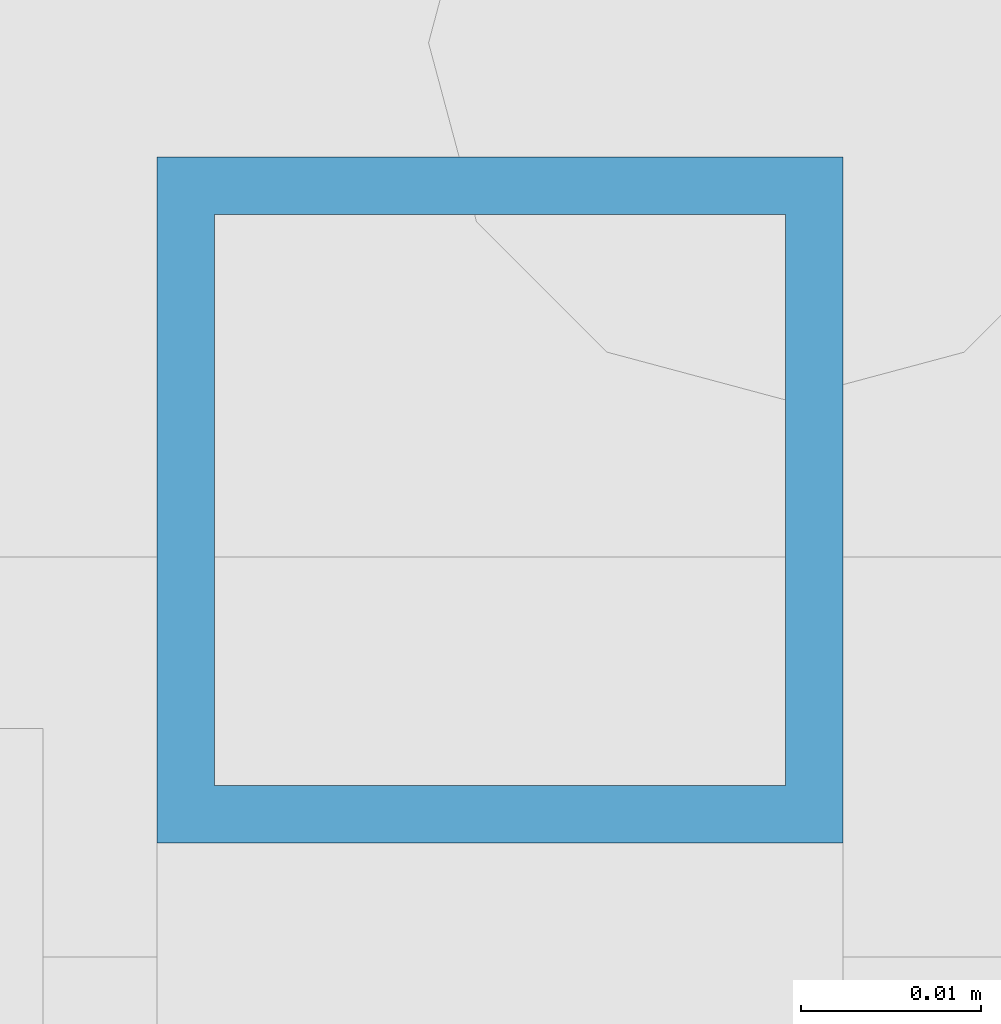
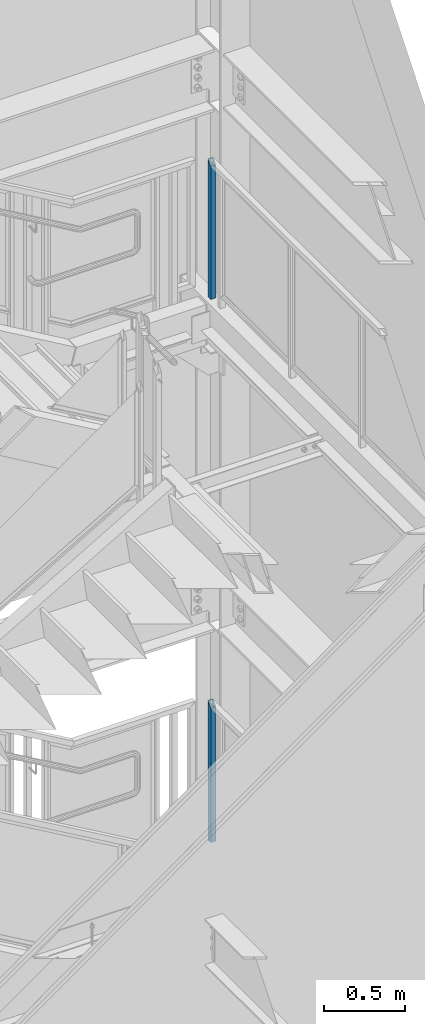
# One storey, part 378 of 1179: 2 columns, 2 elements without a shape of their own.
"""IFC2X3 building model written with IfcOpenShell, lengths in millimetres."""

import ifcopenshell
import ifcopenshell.guid

model = None  # the IFC model being written
_history = None  # IfcOwnerHistory: only IFC2X3 demands one
_inside = {}  # id of a spatial element -> (the spatial element, [elements in it])
_under = {}  # id of a project, library or spatial element -> (it, [spatial elements below it])
_declared = {}  # id of a project -> (the project, [libraries it declares])
_typed = {}  # id of a type object -> (the type object, [elements of that type])
_made_of = {}  # id of a material, layer set ... -> (it, [elements and type objects made of it])


def new_model(schema):
    """Start an empty IFC model of exactly this schema.

    Asked for "IFC4X3", IfcOpenShell would pick the latest addendum, in which some entities
    have other attributes; the version numbers below select the first issue.
    IFC2X3 requires an IfcOwnerHistory on every rooted entity: one is made here for all.
    """
    global model, _history
    if schema == "IFC4X3":
        model = ifcopenshell.file(schema_version=(4, 3, 0, 0))
    else:
        model = ifcopenshell.file(schema=schema)
    _inside.clear()
    _under.clear()
    _declared.clear()
    _typed.clear()
    _made_of.clear()
    _history = None
    if model.schema == "IFC2X3":
        org = make("IfcOrganization", Name="unknown")
        user = make(
            "IfcPersonAndOrganization",
            ThePerson=make("IfcPerson", FamilyName="unknown"),
            TheOrganization=org,
        )
        app = make(
            "IfcApplication",
            ApplicationDeveloper=org,
            Version="unknown",
            ApplicationFullName="unknown",
            ApplicationIdentifier="unknown",
        )
        _history = make(
            "IfcOwnerHistory",
            OwningUser=user,
            OwningApplication=app,
            ChangeAction="ADDED",
            CreationDate=0,
        )
    return model


def make(cls, **values):
    """One entity of the class cls with the attributes given. An attribute that is None is left unset."""
    return model.create_entity(
        cls, **{name: value for name, value in values.items() if value is not None}
    )


def rooted(cls, **values):
    """An entity with a GlobalId (a new one), such as an element, a storey or a relation."""
    return make(cls, GlobalId=ifcopenshell.guid.new(), OwnerHistory=_history, **values)


def si_unit(unit_type, name, prefix=None):
    """IfcSIUnit, for example si_unit("LENGTHUNIT", "METRE", prefix="MILLI")."""
    return make("IfcSIUnit", UnitType=unit_type, Prefix=prefix, Name=name)


def assignment(units):
    """IfcUnitAssignment: the units of a project."""
    return None if units is None else make("IfcUnitAssignment", Units=units)


def point(xyz):
    """IfcCartesianPoint."""
    return None if xyz is None else make("IfcCartesianPoint", Coordinates=xyz)


def direction(xyz):
    """IfcDirection."""
    return None if xyz is None else make("IfcDirection", DirectionRatios=xyz)


def frame(location, z_axis=None, x_axis=None):
    """IfcAxis2Placement3D, a coordinate frame: its origin and axes. An axis left out is left unset."""
    return make(
        "IfcAxis2Placement3D",
        Location=point(location),
        Axis=direction(z_axis),
        RefDirection=direction(x_axis),
    )


def origin_with_axes():
    """The frame at (0, 0, 0) with the z axis (0, 0, 1) and the x axis (1, 0, 0) written out."""
    return frame((0.0, 0.0, 0.0), z_axis=(0.0, 0.0, 1.0), x_axis=(1.0, 0.0, 0.0))


def place(relative_to, where):
    """IfcLocalPlacement: puts the frame where relative to a parent placement (None: the world)."""
    return make(
        "IfcLocalPlacement", PlacementRelTo=relative_to, RelativePlacement=where
    )


def context(
    kind, dimensions, precision=None, world=None, true_north=None, identifier=None
):
    """IfcGeometricRepresentationContext, for example the 3D "Model" context."""
    return make(
        "IfcGeometricRepresentationContext",
        ContextIdentifier=identifier,
        ContextType=kind,
        CoordinateSpaceDimension=dimensions,
        Precision=precision,
        WorldCoordinateSystem=world,
        TrueNorth=true_north,
    )


def subcontext(parent, identifier, kind, view, scale=None):
    """IfcGeometricRepresentationSubContext, for example "Body" below "Model"."""
    return make(
        "IfcGeometricRepresentationSubContext",
        ContextIdentifier=identifier,
        ContextType=kind,
        ParentContext=parent,
        TargetScale=scale,
        TargetView=view,
    )


def project(units=None, contexts=None):
    """IfcProject with its units and contexts."""
    return rooted(
        "IfcProject",
        Name="project",
        RepresentationContexts=contexts,
        UnitsInContext=assignment(units),
    )


def spatial(cls, under=None, at=None, **own):
    """A site, building, storey or space (cls), placed at a placement, below another one or the project."""
    s = rooted(cls, ObjectPlacement=at, **own)
    if under is not None:
        _under.setdefault(under.id(), (under, []))[1].append(s)
    return s


def faces_of(points, faces, orient=None, outer=None):
    """IfcFace entities. A face is a list of loops; a loop is a list of indices into points, from 0.

    orient and outer hold one flag for each loop. By default every Orientation is true, the
    first loop of a face is its IfcFaceOuterBound and the others are IfcFaceBound.
    """
    made = []
    for i, loops in enumerate(faces):
        bounds = []
        for j, loop in enumerate(loops):
            is_outer = j == 0 if outer is None else outer[i][j]
            bounds.append(
                make(
                    "IfcFaceOuterBound" if is_outer else "IfcFaceBound",
                    Bound=make("IfcPolyLoop", Polygon=[points[k] for k in loop]),
                    Orientation=True if orient is None else orient[i][j],
                )
            )
        made.append(make("IfcFace", Bounds=bounds))
    return made


def faceted_brep(points, faces, orient=None, outer=None, voids=None):
    """IfcFacetedBrep: a solid bounded by flat faces; with voids (closed shells), ...WithVoids."""
    shared = [point(p) for p in points]
    hull = make("IfcClosedShell", CfsFaces=faces_of(shared, faces, orient, outer))
    if voids is None:
        return make("IfcFacetedBrep", Outer=hull)
    return make(
        "IfcFacetedBrepWithVoids",
        Outer=hull,
        Voids=[
            make(cls, CfsFaces=faces_of(shared, fs, o, b)) for cls, fs, o, b in voids
        ],
    )


def shape(context_of_items, identifier, shape_type, items):
    """IfcShapeRepresentation: the items that make up one representation, for example the "Body"."""
    return make(
        "IfcShapeRepresentation",
        ContextOfItems=context_of_items,
        RepresentationIdentifier=identifier,
        RepresentationType=shape_type,
        Items=items,
    )


def material(Name=None, Category=None):
    """IfcMaterial."""
    return make("IfcMaterial", Name=Name, Category=Category)


def made_of(thing, what):
    """Note that an element or type object is made of a material, layer set ...; save() writes the relation."""
    if what is not None:
        _made_of.setdefault(what.id(), (what, []))[1].append(thing)
    return thing


def type_object(cls, material=None, **own):
    """A type object (cls), such as IfcWallType, which elements share."""
    return made_of(rooted(cls, **own), material)


def element(
    cls,
    number,
    at=None,
    inside=None,
    cuts=None,
    type_object=None,
    material=None,
    context=None,
    identifier="Body",
    shape_type=None,
    held_by="IfcProductDefinitionShape",
    body=None,
    shapes=None,
    **own,
):
    """One element of the class cls, such as IfcWall. Its Tag is "e" and its number.

    at: its placement. inside: the storey or other place that contains it. cuts: it is an
    opening in that element (IfcRelVoidsElement). A single representation is given by context,
    identifier, shape_type and body (its items); several are given by shapes. held_by: the class
    of the entity that holds the representations. save() writes the other relations.
    """
    e = rooted(cls, Tag="e%d" % number, ObjectPlacement=at, **own)
    if body is not None:
        shapes = [shape(context, identifier, shape_type, body)]
    if shapes is not None:
        e.Representation = make(held_by, Representations=shapes)
    if inside is not None:
        _inside.setdefault(inside.id(), (inside, []))[1].append(e)
    if cuts is not None:
        rooted(
            "IfcRelVoidsElement", RelatingBuildingElement=cuts, RelatedOpeningElement=e
        )
    if type_object is not None:
        _typed.setdefault(type_object.id(), (type_object, []))[1].append(e)
    return made_of(e, material)


def aggregate(whole, parts):
    """IfcRelAggregates: a whole, such as a stair, and the parts it consists of."""
    return rooted("IfcRelAggregates", RelatingObject=whole, RelatedObjects=parts)


def save(model, path):
    """Write the relations noted so far, then the file.

    IfcRelAggregates (storeys below a building ...), IfcRelContainedInSpatialStructure (elements
    in a storey), IfcRelDefinesByType, IfcRelAssociatesMaterial and IfcRelDeclares: one each for
    every whole, place, type object, material and project.
    """
    for whole, parts in _under.values():
        aggregate(whole, parts)
    for where, things in _inside.values():
        rooted(
            "IfcRelContainedInSpatialStructure",
            RelatedElements=things,
            RelatingStructure=where,
        )
    for kind, things in _typed.values():
        rooted("IfcRelDefinesByType", RelatedObjects=things, RelatingType=kind)
    for what, things in _made_of.values():
        rooted("IfcRelAssociatesMaterial", RelatedObjects=things, RelatingMaterial=what)
    for by, libraries in _declared.values():
        rooted("IfcRelDeclares", RelatingContext=by, RelatedDefinitions=libraries)
    model.write(path)


model = new_model("IFC2X3")

# Units and contexts
model_context = context("Model", 3, precision=1e-05, world=origin_with_axes())
body_context = subcontext(model_context, "Body", "Model", "MODEL_VIEW")
ifc_project = project(units=[si_unit("LENGTHUNIT", "METRE", prefix="MILLI"), si_unit("AREAUNIT", "SQUARE_METRE"), si_unit("VOLUMEUNIT", "CUBIC_METRE"), si_unit("MASSUNIT", "GRAM", prefix="KILO"), si_unit("TIMEUNIT", "SECOND"), si_unit("PLANEANGLEUNIT", "RADIAN"), si_unit("SOLIDANGLEUNIT", "STERADIAN"), si_unit("THERMODYNAMICTEMPERATUREUNIT", "DEGREE_CELSIUS"), si_unit("LUMINOUSINTENSITYUNIT", "LUMEN")], contexts=[model_context])

# Site, building, storey
site_placement = place(None, origin_with_axes())
site = spatial("IfcSite", under=ifc_project, at=site_placement, CompositionType="ELEMENT")
building_placement = place(site_placement, origin_with_axes())
building = spatial("IfcBuilding", under=site, at=building_placement, Name="Undefined", CompositionType="ELEMENT")
storey_placement = place(building_placement, origin_with_axes())
storey = spatial("IfcBuildingStorey", under=building, at=storey_placement, Name="Undefined", CompositionType="ELEMENT", Elevation=0.0)

# Assembly, column
assembly_1_placement = place(storey_placement, origin_with_axes())
assembly_1 = element("IfcElementAssembly", 1, at=assembly_1_placement, inside=storey, Name="GUARDRAIL", AssemblyPlace="NOTDEFINED", PredefinedType="RIGID_FRAME")
ifc_material = material()
column_type = type_object("IfcColumnType", Name="HSS1-1/2X1-1/2X1/8", PredefinedType="NOTDEFINED")
column_1_placement = place(assembly_1_placement, frame((24114.1250004143, 40995.6000000007, 6242.05), z_axis=(-1.0, 0.0, 0.0), x_axis=(0.0, 0.0, 1.0)))
column_1 = element("IfcColumn", 2, at=column_1_placement, type_object=column_type, material=ifc_material, Name="POST", ObjectType="HSS1-1/2X1-1/2X1/8", context=body_context, shape_type="Brep", body=[
    faceted_brep([(0.0, 15.8749992830017, -15.8749992829999), (0.0, -15.8749992830017, -15.8749992829999), (1000.12499987055, -15.874999282998, -15.8749992830017), (1031.87499843655, 15.874999282998, -15.8749992830017), (0.0, -15.8749992830017, 15.8749992829999), (1000.12499987055, -15.874999282998, 15.8749992830017), (0.0, 15.8749992830017, 15.8749992829999), (1031.87499843655, 15.874999282998, 15.8749992830017), (0.0, 19.0499992350015, -19.0499992349996), (0.0, 19.0499992350015, 19.0499992349996), (1035.05, 19.0499992350015, 19.0499992350015), (1035.05, 19.0499992350015, -19.0499992350015), (0.0, -19.0499992350015, 19.0499992349996), (996.949999918549, -19.0499992350015, 19.0499992350015), (0.0, -19.0499992350015, -19.0499992349996), (996.949999918549, -19.0499992350015, -19.0499992350015)], [[[0, 1, 2, 3]], [[1, 4, 5, 2]], [[4, 6, 7, 5]], [[6, 0, 3, 7]], [[8, 9, 10, 11]], [[9, 12, 13, 10]], [[12, 14, 15, 13]], [[14, 8, 11, 15]], [[13, 15, 11, 10], [5, 7, 3, 2]], [[14, 12, 9, 8], [6, 4, 1, 0]]]),
])
aggregate(assembly_1, [column_1])

assembly_2_placement = place(storey_placement, origin_with_axes())
assembly_2 = element("IfcElementAssembly", 3, at=assembly_2_placement, inside=storey, Name="GUARDRAIL", AssemblyPlace="NOTDEFINED", PredefinedType="RIGID_FRAME")
column_2_placement = place(assembly_2_placement, frame((24114.1250004143, 40995.6000000007, 2155.825), z_axis=(-1.0, 0.0, 0.0), x_axis=(0.0, 0.0, 1.0)))
column_2 = element("IfcColumn", 4, at=column_2_placement, type_object=column_type, material=ifc_material, Name="POST", ObjectType="HSS1-1/2X1-1/2X1/8", context=body_context, shape_type="Brep", body=[
    faceted_brep([(0.0, 15.8749992830017, -15.8749992829999), (0.0, -15.8749992830017, -15.8749992829999), (1012.82499987055, -15.874999282998, -15.8749992830017), (1044.57499843655, 15.874999282998, -15.8749992830017), (0.0, -15.8749992830017, 15.8749992829999), (1012.82499987055, -15.874999282998, 15.8749992830017), (0.0, 15.8749992830017, 15.8749992829999), (1044.57499843655, 15.874999282998, 15.8749992830017), (0.0, 19.0499992350015, -19.0499992349996), (0.0, 19.0499992350015, 19.0499992349996), (1047.74999838855, 19.0499992350015, 19.0499992350015), (1047.74999838855, 19.0499992350015, -19.0499992350015), (0.0, -19.0499992350015, 19.0499992349996), (1009.64999991855, -19.0499992350015, 19.0499992350015), (0.0, -19.0499992350015, -19.0499992349996), (1009.64999991855, -19.0499992350015, -19.0499992350015)], [[[0, 1, 2, 3]], [[1, 4, 5, 2]], [[4, 6, 7, 5]], [[6, 0, 3, 7]], [[8, 9, 10, 11]], [[9, 12, 13, 10]], [[12, 14, 15, 13]], [[14, 8, 11, 15]], [[13, 15, 11, 10], [5, 7, 3, 2]], [[14, 12, 9, 8], [6, 4, 1, 0]]]),
])
aggregate(assembly_2, [column_2])

save(model, "model.ifc")
